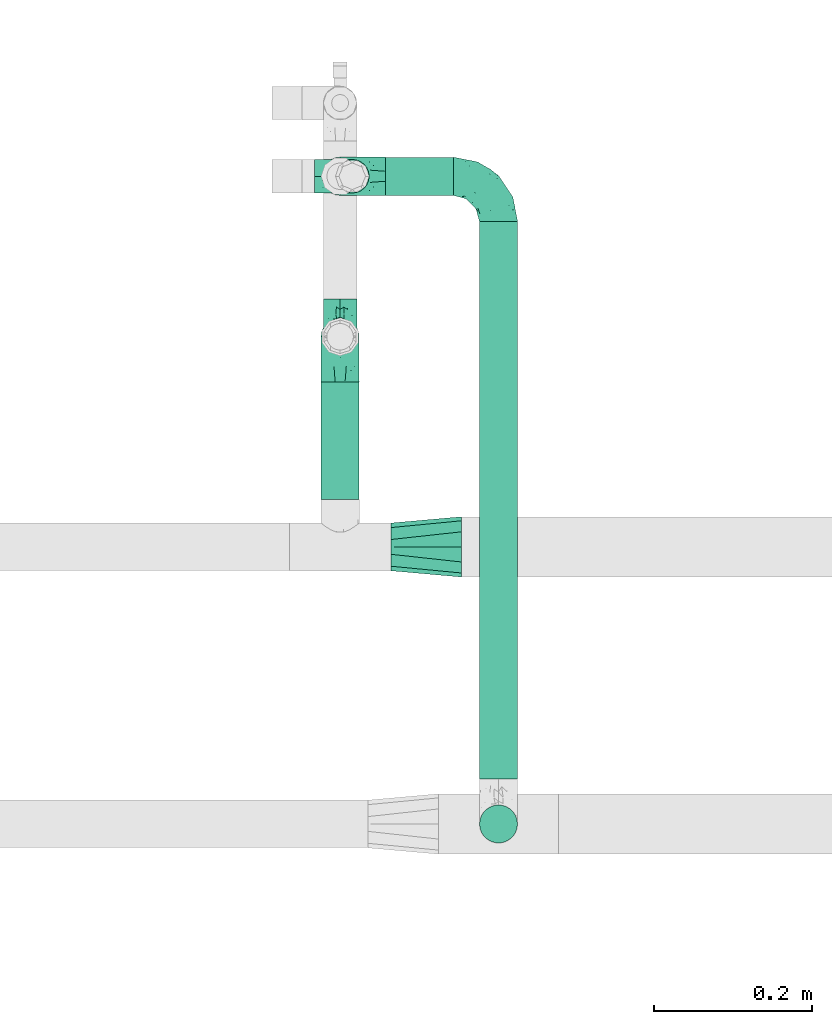
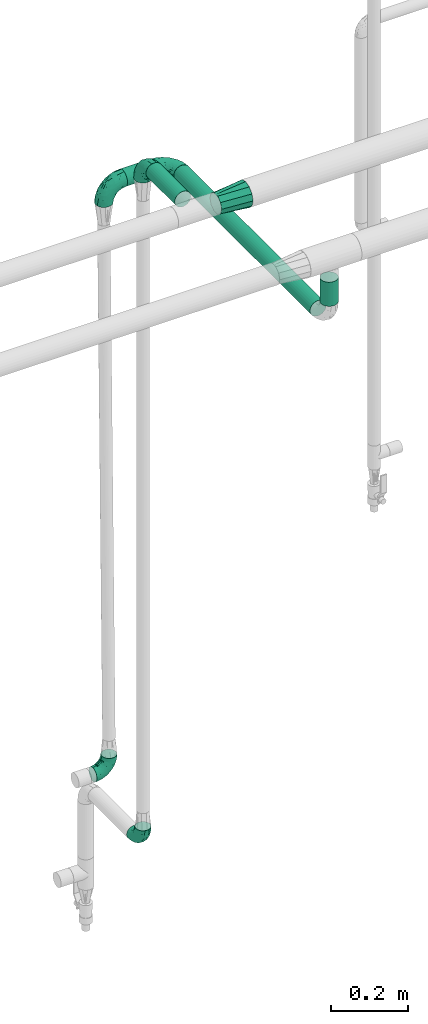
# One storey, part 565 of 827: 6 flow fittings, 4 flow segments.
"""IFC2X3 building model written with IfcOpenShell, lengths in millimetres."""

from ifc_helpers import new_model, entity, si_unit, converted_unit, derived_unit, direction, frame, origin, origin_2d_with_axis, place, context, subcontext, project, spatial, circle, extrude, faceted_brep, source, transform, mapped, material, type_object, type_shapes, element, save


model = new_model("IFC2X3")

# Units and contexts
model_context = context("Model", 3, precision=0.01, world=origin(), true_north=direction((6.12303176911189e-17, 1.0)))
body_context = subcontext(model_context, "Body", "Model", "MODEL_VIEW")
ifc_project = project(units=[si_unit("LENGTHUNIT", "METRE", prefix="MILLI"), si_unit("AREAUNIT", "SQUARE_METRE"), si_unit("VOLUMEUNIT", "CUBIC_METRE"), converted_unit("PLANEANGLEUNIT", "DEGREE", entity("IfcRatioMeasure", 0.0174532925199433), si_unit("PLANEANGLEUNIT", "RADIAN"), dimensions=[0, 0, 0, 0, 0, 0, 0]), si_unit("MASSUNIT", "GRAM", prefix="KILO"), derived_unit("MASSDENSITYUNIT", [(si_unit("MASSUNIT", "GRAM", prefix="KILO"), 1), (si_unit("LENGTHUNIT", "METRE"), -3)]), derived_unit("MOMENTOFINERTIAUNIT", [(si_unit("LENGTHUNIT", "METRE"), 4)]), si_unit("TIMEUNIT", "SECOND"), si_unit("FREQUENCYUNIT", "HERTZ"), si_unit("THERMODYNAMICTEMPERATUREUNIT", "DEGREE_CELSIUS"), derived_unit("THERMALTRANSMITTANCEUNIT", [(si_unit("MASSUNIT", "GRAM", prefix="KILO"), 1), (si_unit("THERMODYNAMICTEMPERATUREUNIT", "KELVIN"), -1), (si_unit("TIMEUNIT", "SECOND"), -3)]), derived_unit("VOLUMETRICFLOWRATEUNIT", [(si_unit("LENGTHUNIT", "METRE"), 3), (si_unit("TIMEUNIT", "SECOND"), -1)]), derived_unit("MASSFLOWRATEUNIT", [(si_unit("MASSUNIT", "GRAM", prefix="KILO"), 1), (si_unit("TIMEUNIT", "SECOND"), -1)]), derived_unit("ROTATIONALFREQUENCYUNIT", [(si_unit("TIMEUNIT", "SECOND"), -1)]), si_unit("ELECTRICCURRENTUNIT", "AMPERE"), si_unit("ELECTRICVOLTAGEUNIT", "VOLT"), si_unit("POWERUNIT", "WATT"), si_unit("FORCEUNIT", "NEWTON", prefix="KILO"), si_unit("ILLUMINANCEUNIT", "LUX"), si_unit("LUMINOUSFLUXUNIT", "LUMEN"), si_unit("LUMINOUSINTENSITYUNIT", "CANDELA"), derived_unit("USERDEFINED", [(si_unit("MASSUNIT", "GRAM", prefix="KILO"), -1), (si_unit("LENGTHUNIT", "METRE"), -2), (si_unit("TIMEUNIT", "SECOND"), 3), (si_unit("LUMINOUSFLUXUNIT", "LUMEN"), 1)]), derived_unit("LINEARVELOCITYUNIT", [(si_unit("LENGTHUNIT", "METRE"), 1), (si_unit("TIMEUNIT", "SECOND"), -1)]), si_unit("PRESSUREUNIT", "PASCAL"), derived_unit("USERDEFINED", [(si_unit("LENGTHUNIT", "METRE"), -2), (si_unit("MASSUNIT", "GRAM", prefix="KILO"), 1), (si_unit("TIMEUNIT", "SECOND"), -2)]), derived_unit("LINEARFORCEUNIT", [(si_unit("MASSUNIT", "GRAM", prefix="KILO"), 1), (si_unit("LENGTHUNIT", "METRE"), 1), (si_unit("TIMEUNIT", "SECOND"), -2), (si_unit("LENGTHUNIT", "METRE"), -1)]), derived_unit("PLANARFORCEUNIT", [(si_unit("MASSUNIT", "GRAM", prefix="KILO"), 1), (si_unit("LENGTHUNIT", "METRE"), 1), (si_unit("TIMEUNIT", "SECOND"), -2), (si_unit("LENGTHUNIT", "METRE"), -2)])], contexts=[model_context])

# Site, building, storey
site_placement = place(None, origin())
site = spatial("IfcSite", under=ifc_project, at=site_placement, CompositionType="ELEMENT")
building_placement = place(site_placement, origin())
building = spatial("IfcBuilding", under=site, at=building_placement, CompositionType="ELEMENT")
storey_placement = place(building_placement, frame((0.0, 0.0, 28200.0)))
storey = spatial("IfcBuildingStorey", under=building, at=storey_placement, Name="08", CompositionType="ELEMENT", Elevation=28200.0)

# Flow segments
pipe_segment_type = type_object("IfcPipeSegmentType", PredefinedType="NOTDEFINED")
flow_segment_1_placement = place(storey_placement, frame((13512.97, 15192.3, 2574.4)))
element("IfcFlowSegment", 1, at=flow_segment_1_placement, inside=storey, type_object=pipe_segment_type, context=body_context, shape_type="SweptSolid", body=[
    extrude(circle(Radius=24.0, at=origin_2d_with_axis()), frame((0.0, 25.6, 25.6), z_axis=(1.0, 0.0, 0.0), x_axis=(0.0, -1.0, 0.0)), (0.0, 0.0, 1.0), 85.9849158073314),
])
flow_segment_2_placement = place(storey_placement, frame((13430.37, 14809.89, 2774.4)))
element("IfcFlowSegment", 2, at=flow_segment_2_placement, inside=storey, type_object=pipe_segment_type, context=body_context, shape_type="SweptSolid", body=[
    extrude(circle(Radius=24.0, at=origin_2d_with_axis()), frame((25.6, 0.0, 25.6), z_axis=(0.0, 1.0, 0.0), x_axis=(1.0, 0.0, 0.0)), (0.0, 0.0, 1.0), 148.314300623279),
])
flow_segment_3_placement = place(storey_placement, frame((13630.36, 14457.0, 2574.4)))
element("IfcFlowSegment", 3, at=flow_segment_3_placement, inside=storey, type_object=pipe_segment_type, context=body_context, shape_type="SweptSolid", body=[
    extrude(circle(Radius=24.0, at=origin_2d_with_axis()), frame((25.6, 0.0, 25.61), z_axis=(0.0, 1.0, -2.41535411879e-05), x_axis=(-1.0, 0.0, 0.0)), (0.0, 0.0, 1.0), 703.896986835568),
])
flow_segment_4_placement = place(storey_placement, frame((13630.36, 14374.4, 2657.01)))
element("IfcFlowSegment", 4, at=flow_segment_4_placement, inside=storey, type_object=pipe_segment_type, context=body_context, shape_type="SweptSolid", body=[
    extrude(circle(Radius=24.0, at=origin_2d_with_axis()), frame((25.6, 25.6, 0.0)), (0.0, 0.0, 1.0), 75.9503658345094),
])

# Flow fittings
ifc_material = material()
pipe_fitting_type_1 = type_object("IfcPipeFittingType", Name="ADSK_1", PredefinedType="NOTDEFINED", material=ifc_material)
shared_shape_1 = source(origin(), body_context, "Body", "Brep", [
    faceted_brep([(-57.0, 12.07, -20.91), (-57.0, 6.25, -23.33), (-57.0, 0.0, -24.15), (-57.0, -6.25, -23.33), (-57.0, -12.08, -20.91), (-57.0, -17.08, -17.08), (-57.0, -20.91, -12.08), (-57.0, -23.33, -6.25), (-57.0, -24.15, 0.0), (-57.0, -23.33, 6.25), (-57.0, -20.91, 12.07), (-57.0, -17.08, 17.08), (-57.0, -12.08, 20.91), (-57.0, -6.25, 23.33), (-57.0, 0.0, 24.15), (-57.0, 6.25, 23.33), (-57.0, 12.07, 20.91), (-57.0, 17.08, 17.08), (-57.0, 20.91, 12.07), (-57.0, 23.33, 6.25), (-57.0, 24.15, 0.0), (-57.0, 23.33, -6.25), (-57.0, 20.91, -12.08), (-57.0, 17.08, -17.08), (0.0, 57.0, -24.15), (-6.25, 57.0, -23.33), (-12.07, 57.0, -20.91), (-17.08, 57.0, -17.08), (-20.91, 57.0, -12.08), (-23.33, 57.0, -6.25), (-24.15, 57.0, 0.0), (-23.33, 57.0, 6.25), (-20.91, 57.0, 12.07), (-17.08, 57.0, 17.08), (-12.07, 57.0, 20.91), (-6.25, 57.0, 23.33), (0.0, 57.0, 24.15), (6.25, 57.0, 23.33), (12.08, 57.0, 20.91), (17.08, 57.0, 17.08), (20.91, 57.0, 12.07), (23.33, 57.0, 6.25), (24.15, 57.0, 0.0), (23.33, 57.0, -6.25), (20.91, 57.0, -12.08), (17.08, 57.0, -17.08), (12.08, 57.0, -20.91), (6.25, 57.0, -23.33), (14.9, 21.14, 6.17), (13.61, 24.64, 12.48), (6.23, 8.95, 8.98), (-41.47, -21.06, 0.0), (-41.92, -18.38, 13.72), (-24.64, -13.61, 12.48), (-37.37, -13.24, 18.15), (-6.8, -4.93, 8.18), (-21.76, -15.19, 6.22), (-12.78, -9.18, 0.0), (-37.73, -20.51, 7.75), (-7.38, 7.38, 20.24), (-23.37, -4.26, 20.42), (-11.9, -3.19, 15.86), (-42.14, -8.7, 21.82), (13.24, 37.37, 18.15), (9.33, 23.53, 16.85), (4.26, 23.37, 20.42), (2.77, 10.92, 15.55), (-29.46, 0.91, 23.52), (-44.13, 20.56, 15.69), (-39.25, 26.33, 10.88), (-49.02, 22.92, 9.96), (-34.58, 23.87, 17.15), (-15.8, 6.8, 22.81), (-8.67, 20.47, 23.88), (-18.12, 12.9, 24.08), (-48.29, 14.92, 19.65), (-44.06, -2.85, 23.78), (-9.23, 48.95, 22.58), (-3.78, 42.74, 24.07), (-40.34, 4.26, 24.09), (-44.02, 26.14, 5.46), (-44.04, 9.88, 22.74), (-4.95, 16.87, 22.52), (-2.75, 1.43, 12.5), (-25.48, 40.98, 10.71), (20.51, 37.73, 7.75), (18.38, 41.92, 13.72), (8.7, 42.14, 21.82), (-25.95, -17.97, 0.0), (2.85, 44.06, 23.78), (21.06, 41.47, 0.0), (17.97, 25.95, 0.0), (-24.04, -9.27, 17.13), (-33.26, 33.26, 5.86), (-28.55, 40.57, 0.0), (-40.57, 28.55, 0.0), (-25.29, 47.19, 4.06), (-27.01, 31.1, 16.77), (-15.7, 43.95, 19.9), (-20.27, 45.22, 15.61), (-30.53, 31.98, 12.64), (-11.28, 38.33, 22.92), (-9.97, 27.88, 24.09), (-20.15, 30.26, 21.25), (-31.25, 11.75, 23.64), (-28.75, 7.23, 24.15), (-29.53, 18.06, 22.27), (-28.44, 24.21, 20.02), (-37.55, 17.7, 20.26), (-15.88, 29.25, 22.99), (-20.82, 20.82, 23.44), (-0.91, 29.46, 23.52), (-13.5, -7.67, 12.04), (1.49, 1.56, 5.16), (8.86, 10.35, 4.59), (0.38, -0.38, 0.0), (9.18, 12.78, 0.0), (-37.37, -13.24, -18.15), (8.86, 10.35, -4.59), (-45.22, 20.27, -15.61), (-43.95, 15.7, -19.9), (-38.33, 11.28, -22.92), (-48.95, 9.23, -22.58), (-47.19, 25.29, -4.06), (-33.26, 33.26, -5.86), (18.38, 41.92, -13.72), (-30.26, 20.15, -21.25), (2.85, 44.06, -23.78), (-4.26, 40.34, -24.09), (-40.98, 25.48, -10.71), (-41.92, -18.38, -13.72), (9.25, 23.5, -16.92), (4.26, 23.37, -20.42), (13.24, 37.37, -18.15), (-37.73, -20.51, -7.75), (-11.75, 31.25, -23.64), (-7.23, 28.75, -24.15), (-12.9, 18.12, -24.08), (8.7, 42.14, -21.82), (-44.06, -2.85, -23.78), (-6.8, 15.8, -22.81), (-20.47, 8.67, -23.88), (-24.64, -13.61, -12.48), (-42.74, 3.78, -24.07), (-18.06, 29.53, -22.27), (-24.21, 28.44, -20.02), (-27.88, 9.97, -24.09), (-31.1, 27.01, -16.77), (-26.14, 44.02, -5.46), (14.9, 21.14, -6.17), (20.51, 37.73, -7.75), (-9.88, 44.04, -22.74), (-20.56, 44.13, -15.69), (-21.76, -15.19, -6.22), (-13.5, -7.67, -12.04), (-24.14, -9.76, -16.74), (-11.9, -3.19, -15.86), (-14.92, 48.29, -19.65), (-23.37, -4.26, -20.42), (-0.91, 29.46, -23.52), (-26.33, 39.25, -10.88), (-23.87, 34.58, -17.15), (-42.14, -8.7, -21.82), (-22.92, 49.02, -9.96), (13.61, 24.64, -12.48), (-31.98, 30.53, -12.64), (-16.87, 4.95, -22.52), (-17.7, 37.55, -20.26), (-29.25, 15.88, -22.99), (-20.82, 20.82, -23.44), (-29.46, 0.91, -23.52), (-7.38, 7.38, -20.24), (2.77, 10.92, -15.55), (6.23, 8.95, -8.98), (-6.8, -4.93, -8.18), (-2.81, 1.41, -12.54), (1.49, 1.56, -5.16)], [[[0, 1, 2, 3, 4, 5, 6, 7, 8, 9, 10, 11, 12, 13, 14, 15, 16, 17, 18, 19, 20, 21, 22, 23]], [[24, 25, 26, 27, 28, 29, 30, 31, 32, 33, 34, 35, 36, 37, 38, 39, 40, 41, 42, 43, 44, 45, 46, 47]], [[48, 49, 50]], [[9, 8, 51]], [[52, 53, 54]], [[55, 56, 57]], [[10, 58, 52]], [[9, 58, 10]], [[59, 60, 61]], [[54, 12, 11]], [[54, 62, 12]], [[63, 39, 38]], [[64, 65, 66]], [[62, 60, 67]], [[68, 69, 70]], [[71, 69, 68]], [[72, 73, 74]], [[16, 75, 17]], [[13, 76, 14]], [[35, 77, 78]], [[14, 79, 15]], [[17, 68, 18]], [[14, 76, 79]], [[20, 19, 80]], [[70, 19, 18]], [[81, 15, 79]], [[15, 81, 16]], [[73, 72, 82]], [[66, 83, 50]], [[32, 31, 84]], [[85, 86, 49]], [[63, 87, 65]], [[56, 58, 88]], [[36, 89, 37]], [[85, 41, 40]], [[36, 35, 78]], [[90, 41, 85]], [[40, 39, 86]], [[12, 62, 13]], [[86, 85, 40]], [[48, 85, 49]], [[85, 91, 90]], [[87, 38, 37]], [[92, 60, 54]], [[80, 69, 93]], [[93, 94, 95]], [[10, 52, 11]], [[94, 96, 30]], [[97, 98, 99]], [[80, 93, 95]], [[100, 97, 84]], [[99, 98, 33]], [[101, 102, 78]], [[103, 101, 98]], [[96, 31, 30]], [[77, 98, 101]], [[77, 35, 34]], [[34, 33, 98]], [[9, 51, 58]], [[87, 63, 38]], [[104, 105, 74]], [[106, 103, 107]], [[106, 81, 104]], [[75, 68, 17]], [[108, 107, 71]], [[33, 32, 99]], [[109, 103, 110]], [[101, 109, 102]], [[89, 78, 111]], [[53, 52, 58]], [[54, 11, 52]], [[60, 62, 54]], [[88, 58, 51]], [[76, 62, 67]], [[53, 112, 92]], [[60, 59, 72]], [[39, 63, 86]], [[49, 86, 63]], [[89, 87, 37]], [[42, 41, 90]], [[111, 82, 65]], [[111, 65, 87]], [[65, 59, 66]], [[104, 81, 79]], [[75, 81, 108]], [[32, 84, 99]], [[97, 99, 84]], [[98, 97, 103]], [[106, 107, 108]], [[74, 102, 110]], [[111, 78, 102]], [[74, 110, 104]], [[74, 67, 72]], [[61, 92, 112]], [[66, 59, 61]], [[56, 53, 58]], [[66, 50, 49]], [[61, 112, 83]], [[66, 49, 64]], [[78, 89, 36]], [[87, 89, 111]], [[62, 76, 13]], [[79, 76, 67]], [[100, 93, 69]], [[96, 93, 84]], [[55, 113, 50]], [[113, 114, 50]], [[104, 79, 105]], [[106, 104, 110]], [[20, 80, 95]], [[85, 48, 91]], [[115, 114, 113]], [[116, 91, 48]], [[70, 80, 19]], [[93, 96, 94]], [[84, 31, 96]], [[103, 106, 110]], [[81, 106, 108]], [[103, 97, 107]], [[71, 107, 97]], [[71, 97, 100]], [[108, 71, 68]], [[79, 67, 105]], [[67, 74, 105]], [[115, 113, 57]], [[112, 56, 55]], [[56, 88, 57]], [[60, 72, 67]], [[82, 72, 59]], [[65, 82, 59]], [[82, 111, 73]], [[111, 102, 73]], [[102, 74, 73]], [[81, 75, 16]], [[68, 75, 108]], [[68, 70, 18]], [[80, 70, 69]], [[98, 77, 34]], [[78, 77, 101]], [[93, 100, 84]], [[71, 100, 69]], [[102, 109, 110]], [[101, 103, 109]], [[53, 92, 54]], [[61, 60, 92]], [[56, 112, 53]], [[83, 112, 55]], [[50, 83, 55]], [[61, 83, 66]], [[49, 63, 64]], [[65, 64, 63]], [[57, 113, 55]], [[114, 115, 116]], [[116, 48, 114]], [[48, 50, 114]], [[117, 5, 4]], [[116, 115, 118]], [[119, 120, 23]], [[121, 122, 120]], [[95, 123, 20]], [[0, 23, 120]], [[124, 95, 94]], [[125, 45, 44]], [[121, 120, 126]], [[24, 127, 128]], [[22, 21, 129]], [[0, 122, 1]], [[5, 117, 130]], [[131, 132, 133]], [[134, 88, 51]], [[135, 136, 137]], [[6, 5, 130]], [[46, 138, 47]], [[139, 3, 2]], [[140, 141, 137]], [[6, 134, 7]], [[134, 130, 142]], [[143, 2, 1]], [[144, 126, 145]], [[121, 146, 143]], [[147, 120, 119]], [[94, 148, 124]], [[149, 150, 91]], [[30, 29, 148]], [[151, 25, 128]], [[27, 152, 28]], [[134, 153, 88]], [[154, 155, 156]], [[27, 26, 157]], [[151, 26, 25]], [[155, 158, 156]], [[24, 47, 127]], [[1, 122, 143]], [[138, 132, 159]], [[160, 152, 161]], [[24, 128, 25]], [[46, 133, 138]], [[162, 117, 4]], [[148, 160, 124]], [[152, 160, 163]], [[154, 142, 155]], [[45, 125, 133]], [[133, 46, 45]], [[125, 164, 133]], [[51, 7, 134]], [[42, 90, 43]], [[165, 147, 129]], [[153, 134, 142]], [[43, 150, 44]], [[162, 4, 3]], [[141, 140, 166]], [[117, 162, 158]], [[163, 29, 28]], [[43, 90, 150]], [[123, 21, 20]], [[144, 151, 135]], [[157, 152, 27]], [[167, 145, 161]], [[23, 22, 119]], [[168, 126, 169]], [[121, 168, 146]], [[139, 143, 170]], [[142, 130, 117]], [[8, 7, 51]], [[134, 6, 130]], [[139, 162, 3]], [[170, 166, 158]], [[170, 158, 162]], [[158, 171, 156]], [[44, 150, 125]], [[91, 150, 90]], [[164, 125, 150]], [[132, 138, 133]], [[127, 138, 159]], [[131, 164, 172]], [[132, 171, 140]], [[135, 151, 128]], [[157, 151, 167]], [[22, 129, 119]], [[147, 119, 129]], [[120, 147, 126]], [[144, 145, 167]], [[137, 146, 169]], [[170, 143, 146]], [[137, 169, 135]], [[137, 159, 140]], [[171, 172, 156]], [[173, 174, 175]], [[156, 175, 154]], [[174, 57, 153]], [[132, 172, 171]], [[172, 164, 173]], [[143, 139, 2]], [[162, 139, 170]], [[138, 127, 47]], [[128, 127, 159]], [[165, 124, 160]], [[123, 124, 129]], [[149, 173, 164]], [[176, 174, 173]], [[135, 128, 136]], [[144, 135, 169]], [[150, 149, 164]], [[176, 118, 115]], [[149, 91, 116]], [[30, 148, 94]], [[163, 148, 29]], [[124, 123, 95]], [[129, 21, 123]], [[126, 144, 169]], [[151, 144, 167]], [[126, 147, 145]], [[161, 145, 147]], [[161, 147, 165]], [[167, 161, 152]], [[128, 159, 136]], [[159, 137, 136]], [[154, 153, 142]], [[132, 140, 159]], [[174, 176, 57]], [[57, 88, 153]], [[166, 140, 171]], [[158, 166, 171]], [[166, 170, 141]], [[170, 146, 141]], [[146, 137, 141]], [[151, 157, 26]], [[152, 157, 167]], [[152, 163, 28]], [[148, 163, 160]], [[120, 122, 0]], [[143, 122, 121]], [[124, 165, 129]], [[161, 165, 160]], [[146, 168, 169]], [[121, 126, 168]], [[142, 117, 155]], [[158, 155, 117]], [[175, 156, 172]], [[153, 154, 174]], [[173, 175, 172]], [[174, 154, 175]], [[164, 131, 133]], [[172, 132, 131]], [[176, 173, 118]], [[57, 176, 115]], [[173, 149, 118]], [[149, 116, 118]]]),
])
type_shapes(pipe_fitting_type_1, [shared_shape_1])
for number, where, z_axis, x_axis, name in (
    (5, (13455.97, 15217.9, 2600.0), (0.0, 1.0, 0.0), (0.0, 0.0, 1.0), "ADSK_1"),
    (6, (13655.95, 15217.9, 2600.0), (0.0, 0.0, 1.0), (0.0, 1.0, 0.0), "ADSK_1"),
    (7, (13455.97, 15015.21, 2800.0), (-1.0, 0.0, 0.0), (0.0, 1.0, 0.0), "ADSK_1"),
):
    element("IfcFlowFitting", number, at=place(storey_placement, frame(where, z_axis=z_axis, x_axis=x_axis)), inside=storey, type_object=pipe_fitting_type_1, material=ifc_material, Name=name, ObjectType="ADSK_1", context=body_context, shape_type="MappedRepresentation", body=[
        mapped(shared_shape_1, transform((0.0, 0.0, 0.0), scale=1.0)),
    ])
pipe_fitting_type_2 = type_object("IfcPipeFittingType", Name="ADSK_1", PredefinedType="NOTDEFINED", material=ifc_material)
shared_shape_2 = source(origin(), body_context, "Body", "Brep", [
    faceted_brep([(-48.0, 10.6, -18.36), (-48.0, 5.49, -20.48), (-48.0, 0.0, -21.2), (-48.0, -5.49, -20.48), (-48.0, -10.6, -18.36), (-48.0, -14.99, -14.99), (-48.0, -18.36, -10.6), (-48.0, -20.48, -5.49), (-48.0, -21.2, 0.0), (-48.0, -20.48, 5.49), (-48.0, -18.36, 10.6), (-48.0, -14.99, 14.99), (-48.0, -10.6, 18.36), (-48.0, -5.49, 20.48), (-48.0, 0.0, 21.2), (-48.0, 5.49, 20.48), (-48.0, 10.6, 18.36), (-48.0, 14.99, 14.99), (-48.0, 18.36, 10.6), (-48.0, 20.48, 5.49), (-48.0, 21.2, 0.0), (-48.0, 20.48, -5.49), (-48.0, 18.36, -10.6), (-48.0, 14.99, -14.99), (0.0, 48.0, -21.2), (-5.49, 48.0, -20.48), (-10.6, 48.0, -18.36), (-14.99, 48.0, -14.99), (-18.36, 48.0, -10.6), (-20.48, 48.0, -5.49), (-21.2, 48.0, 0.0), (-20.48, 48.0, 5.49), (-18.36, 48.0, 10.6), (-14.99, 48.0, 14.99), (-10.6, 48.0, 18.36), (-5.49, 48.0, 20.48), (0.0, 48.0, 21.2), (5.49, 48.0, 20.48), (10.6, 48.0, 18.36), (14.99, 48.0, 14.99), (18.36, 48.0, 10.6), (20.48, 48.0, 5.49), (21.2, 48.0, 0.0), (20.48, 48.0, -5.49), (18.36, 48.0, -10.6), (14.99, 48.0, -14.99), (10.6, 48.0, -18.36), (5.49, 48.0, -20.48), (-35.25, -16.22, 12.01), (-34.76, -18.57, 0.0), (-20.87, -12.37, 10.9), (-31.49, -11.78, 15.9), (-37.0, -2.58, 20.86), (-33.89, 3.62, 21.15), (-31.81, -18.14, 6.76), (-5.78, 5.78, 17.67), (-19.42, -4.1, 17.86), (-9.6, -3.39, 13.73), (-35.44, -7.73, 19.13), (11.78, 31.49, 15.9), (-5.93, -5.46, 6.95), (-18.45, -13.78, 5.46), (-10.29, -8.43, 0.0), (-24.6, 0.55, 20.62), (-37.28, 17.94, 13.81), (-33.38, 22.85, 9.59), (-41.46, 20.06, 8.75), (-29.51, 20.45, 15.16), (-15.04, 10.79, 21.13), (-7.08, 16.98, 20.93), (-8.39, 23.51, 21.15), (-40.86, 13.03, 17.26), (-8.05, 41.26, 19.83), (-3.21, 35.97, 21.14), (8.53, 19.66, 14.74), (4.1, 19.42, 17.86), (-37.72, 22.66, 4.78), (-37.07, 8.58, 19.98), (-13.0, 5.43, 19.97), (-3.78, 13.93, 19.7), (3.02, 8.69, 13.43), (-2.27, -0.05, 10.65), (6.22, 6.99, 7.09), (-22.25, 34.6, 9.45), (18.14, 31.81, 6.76), (16.22, 35.25, 12.01), (12.37, 20.87, 10.9), (7.73, 35.44, 19.13), (-21.52, -15.93, 0.0), (2.58, 37.0, 20.86), (18.57, 34.76, 0.0), (13.78, 18.45, 5.46), (15.93, 21.52, 0.0), (-20.03, -8.54, 14.9), (-28.6, 28.6, 5.16), (-24.79, 34.6, 0.0), (-34.6, 24.79, 0.0), (-22.81, 37.41, 4.68), (-23.36, 26.33, 14.79), (-13.68, 37.05, 17.49), (-17.72, 38.12, 13.73), (-26.25, 27.3, 11.24), (-9.71, 32.34, 20.14), (-17.26, 25.6, 18.71), (-26.33, 9.99, 20.77), (-24.06, 6.05, 21.2), (-25.02, 15.46, 19.56), (-24.3, 20.72, 17.57), (-31.95, 15.23, 17.8), (-13.53, 24.7, 20.21), (-17.6, 17.6, 20.6), (-0.55, 24.6, 20.62), (-11.41, -7.48, 10.43), (0.93, -0.93, 0.0), (8.43, 10.29, 0.0), (-11.41, -7.48, -10.43), (-20.1, -8.84, -14.66), (-9.6, -3.39, -13.73), (7.73, 35.44, -19.13), (4.1, 19.42, -17.86), (-0.55, 24.6, -20.62), (-38.12, 17.72, -13.73), (-37.05, 13.68, -17.49), (-32.34, 9.71, -20.14), (-41.26, 8.05, -19.83), (-37.41, 22.81, -4.68), (-23.51, 8.39, -21.15), (-35.97, 3.21, -21.14), (-28.6, 28.6, -5.16), (-31.81, -18.14, -6.76), (-18.45, -13.78, -5.46), (-25.6, 17.26, -18.71), (-19.42, -4.1, -17.86), (-17.94, 37.28, -13.81), (-22.85, 33.38, -9.59), (-20.06, 41.46, -8.75), (-31.49, -11.78, -15.9), (-35.25, -16.22, -12.01), (8.53, 19.66, -14.74), (11.78, 31.49, -15.9), (-9.99, 26.33, -20.77), (-6.05, 24.06, -21.2), (-10.79, 15.04, -21.13), (-37.0, -2.58, -20.86), (-16.98, 7.08, -20.93), (-5.43, 13.0, -19.97), (-13.93, 3.78, -19.7), (-20.87, -12.37, -10.9), (-26.33, 23.36, -14.79), (-22.66, 37.72, -4.78), (13.78, 18.45, -5.46), (18.14, 31.81, -6.76), (-15.46, 25.02, -19.56), (-20.72, 24.3, -17.57), (16.22, 35.25, -12.01), (-13.03, 40.86, -17.26), (-8.58, 37.07, -19.98), (2.58, 37.0, -20.86), (-3.62, 33.89, -21.15), (-34.6, 22.25, -9.45), (6.22, 6.99, -7.09), (-20.45, 29.51, -15.16), (-35.44, -7.73, -19.13), (12.37, 20.87, -10.9), (-27.3, 26.25, -11.24), (-15.23, 31.95, -17.8), (-24.7, 13.53, -20.21), (-24.6, 0.55, -20.62), (-5.78, 5.78, -17.67), (-17.6, 17.6, -20.6), (3.02, 8.69, -13.43), (-5.93, -5.46, -6.95), (-2.27, -0.05, -10.65)], [[[0, 1, 2, 3, 4, 5, 6, 7, 8, 9, 10, 11, 12, 13, 14, 15, 16, 17, 18, 19, 20, 21, 22, 23]], [[24, 25, 26, 27, 28, 29, 30, 31, 32, 33, 34, 35, 36, 37, 38, 39, 40, 41, 42, 43, 44, 45, 46, 47]], [[10, 48, 11]], [[9, 8, 49]], [[48, 50, 51]], [[14, 52, 53]], [[10, 54, 48]], [[9, 54, 10]], [[55, 56, 57]], [[51, 12, 11]], [[51, 58, 12]], [[59, 39, 38]], [[60, 61, 62]], [[58, 56, 63]], [[64, 65, 66]], [[67, 65, 64]], [[68, 69, 70]], [[16, 71, 17]], [[13, 52, 14]], [[35, 72, 73]], [[14, 53, 15]], [[17, 64, 18]], [[74, 59, 75]], [[20, 19, 76]], [[66, 19, 18]], [[77, 15, 53]], [[15, 77, 16]], [[69, 78, 79]], [[80, 81, 82]], [[32, 31, 83]], [[84, 85, 86]], [[59, 87, 75]], [[61, 54, 88]], [[36, 89, 37]], [[84, 41, 40]], [[36, 35, 73]], [[90, 41, 84]], [[40, 39, 85]], [[12, 58, 13]], [[85, 84, 40]], [[91, 84, 86]], [[84, 92, 90]], [[87, 38, 37]], [[93, 56, 51]], [[65, 94, 76]], [[94, 95, 96]], [[84, 91, 92]], [[95, 97, 30]], [[98, 99, 100]], [[76, 94, 96]], [[101, 98, 83]], [[100, 99, 33]], [[102, 70, 73]], [[103, 102, 99]], [[94, 97, 95]], [[72, 99, 102]], [[72, 35, 34]], [[34, 33, 99]], [[9, 49, 54]], [[87, 59, 38]], [[104, 105, 68]], [[106, 103, 107]], [[106, 77, 104]], [[71, 64, 17]], [[108, 107, 67]], [[33, 32, 100]], [[109, 103, 110]], [[102, 109, 70]], [[89, 73, 111]], [[50, 48, 54]], [[51, 11, 48]], [[56, 58, 51]], [[88, 54, 49]], [[52, 58, 63]], [[50, 112, 93]], [[56, 55, 78]], [[39, 59, 85]], [[86, 85, 59]], [[89, 87, 37]], [[42, 41, 90]], [[111, 79, 75]], [[111, 75, 87]], [[75, 55, 80]], [[104, 77, 53]], [[71, 77, 108]], [[32, 83, 100]], [[98, 100, 83]], [[99, 98, 103]], [[106, 107, 108]], [[68, 70, 110]], [[111, 73, 70]], [[68, 110, 104]], [[68, 63, 78]], [[57, 93, 112]], [[80, 55, 57]], [[61, 50, 54]], [[80, 82, 86]], [[81, 57, 112]], [[74, 86, 59]], [[60, 113, 82]], [[82, 114, 91]], [[101, 94, 65]], [[97, 94, 83]], [[73, 89, 36]], [[87, 89, 111]], [[58, 52, 13]], [[53, 52, 63]], [[104, 53, 105]], [[106, 104, 110]], [[20, 76, 96]], [[76, 19, 66]], [[103, 106, 110]], [[77, 106, 108]], [[103, 98, 107]], [[67, 107, 98]], [[67, 98, 101]], [[108, 67, 64]], [[53, 63, 105]], [[63, 68, 105]], [[83, 31, 97]], [[30, 97, 31]], [[62, 113, 60]], [[112, 61, 60]], [[61, 88, 62]], [[86, 82, 91]], [[56, 78, 63]], [[114, 82, 113]], [[114, 92, 91]], [[79, 78, 55]], [[75, 79, 55]], [[69, 79, 111]], [[70, 69, 111]], [[78, 69, 68]], [[77, 71, 16]], [[64, 71, 108]], [[64, 66, 18]], [[76, 66, 65]], [[99, 72, 34]], [[73, 72, 102]], [[94, 101, 83]], [[67, 101, 65]], [[75, 80, 74]], [[80, 86, 74]], [[70, 109, 110]], [[102, 103, 109]], [[50, 93, 51]], [[57, 56, 93]], [[61, 112, 50]], [[81, 112, 60]], [[82, 81, 60]], [[80, 57, 81]], [[115, 116, 117]], [[118, 119, 120]], [[121, 122, 23]], [[123, 124, 122]], [[96, 125, 20]], [[123, 126, 127]], [[128, 96, 95]], [[129, 130, 88]], [[123, 122, 131]], [[116, 132, 117]], [[133, 134, 135]], [[0, 124, 1]], [[5, 136, 137]], [[138, 119, 139]], [[129, 88, 49]], [[140, 141, 142]], [[6, 5, 137]], [[46, 118, 47]], [[143, 3, 2]], [[144, 145, 146]], [[6, 129, 7]], [[129, 137, 147]], [[127, 2, 1]], [[148, 122, 121]], [[128, 125, 96]], [[134, 128, 149]], [[95, 149, 128]], [[150, 151, 92]], [[30, 29, 149]], [[152, 131, 153]], [[27, 133, 28]], [[154, 45, 44]], [[136, 5, 4]], [[27, 26, 155]], [[156, 26, 25]], [[24, 157, 158]], [[24, 47, 157]], [[22, 21, 159]], [[160, 150, 114]], [[134, 133, 161]], [[142, 144, 126]], [[46, 139, 118]], [[162, 136, 4]], [[156, 25, 158]], [[1, 124, 127]], [[115, 147, 116]], [[45, 154, 139]], [[139, 46, 45]], [[154, 163, 139]], [[162, 4, 3]], [[42, 90, 43]], [[130, 129, 147]], [[49, 7, 129]], [[43, 151, 44]], [[0, 23, 122]], [[24, 158, 25]], [[136, 162, 132]], [[135, 29, 28]], [[43, 90, 151]], [[164, 148, 159]], [[152, 156, 140]], [[155, 133, 27]], [[165, 153, 161]], [[23, 22, 121]], [[123, 131, 166]], [[123, 166, 126]], [[143, 127, 167]], [[147, 137, 136]], [[8, 7, 49]], [[129, 6, 137]], [[143, 162, 3]], [[167, 146, 132]], [[167, 132, 162]], [[132, 168, 117]], [[44, 151, 154]], [[92, 151, 90]], [[163, 154, 151]], [[119, 118, 139]], [[157, 118, 120]], [[138, 139, 163]], [[119, 168, 145]], [[140, 156, 158]], [[155, 156, 165]], [[22, 159, 121]], [[148, 121, 159]], [[122, 148, 131]], [[152, 153, 165]], [[142, 126, 169]], [[167, 127, 126]], [[142, 169, 140]], [[142, 120, 145]], [[168, 170, 117]], [[160, 171, 172]], [[115, 172, 171]], [[171, 62, 130]], [[119, 170, 168]], [[170, 163, 160]], [[150, 163, 151]], [[113, 171, 160]], [[164, 128, 134]], [[125, 128, 159]], [[127, 143, 2]], [[162, 143, 167]], [[118, 157, 47]], [[158, 157, 120]], [[140, 158, 141]], [[152, 140, 169]], [[30, 149, 95]], [[149, 29, 135]], [[131, 152, 169]], [[156, 152, 165]], [[131, 148, 153]], [[161, 153, 148]], [[161, 148, 164]], [[165, 161, 133]], [[158, 120, 141]], [[120, 142, 141]], [[159, 21, 125]], [[20, 125, 21]], [[115, 130, 147]], [[114, 113, 160]], [[62, 171, 113]], [[62, 88, 130]], [[160, 163, 150]], [[150, 92, 114]], [[119, 145, 120]], [[146, 145, 168]], [[132, 146, 168]], [[144, 146, 167]], [[126, 144, 167]], [[145, 144, 142]], [[156, 155, 26]], [[133, 155, 165]], [[133, 135, 28]], [[149, 135, 134]], [[122, 124, 0]], [[127, 124, 123]], [[128, 164, 159]], [[161, 164, 134]], [[163, 170, 138]], [[170, 119, 138]], [[131, 169, 166]], [[126, 166, 169]], [[147, 136, 116]], [[132, 116, 136]], [[172, 115, 117]], [[130, 115, 171]], [[117, 170, 172]], [[160, 172, 170]]]),
])
type_shapes(pipe_fitting_type_2, [shared_shape_2])
for number, where, z_axis, x_axis, name in (
    (8, (13455.97, 15015.21, 650.0), (-1.0, 0.0, 0.0), (0.0, -1.0, 0.0), "ADSK_1"),
    (9, (13471.37, 15217.9, 750.0), (0.0, -1.0, 0.0), (1.0, 0.0, 0.0), "ADSK_1"),
):
    element("IfcFlowFitting", number, at=place(storey_placement, frame(where, z_axis=z_axis, x_axis=x_axis)), inside=storey, type_object=pipe_fitting_type_2, material=ifc_material, Name=name, ObjectType="ADSK_1", context=body_context, shape_type="MappedRepresentation", body=[
        mapped(shared_shape_2, transform((0.0, 0.0, 0.0), scale=1.0)),
    ])
pipe_fitting_type_3 = type_object("IfcPipeFittingType", Name="ADSK_1", PredefinedType="NOTDEFINED", material=ifc_material)
shared_shape_3 = source(origin(), body_context, "Body", "Brep", [
    faceted_brep([(89.0, 32.95, -19.02), (89.0, 36.11, -7.24), (89.0, 38.05, 0.0), (89.0, 36.11, 7.24), (89.0, 32.95, 19.03), (89.0, 25.99, 25.99), (89.0, 19.02, 32.95), (89.0, 9.51, 35.5), (89.0, 0.0, 38.05), (89.0, -9.51, 35.5), (89.0, -19.03, 32.95), (89.0, -25.99, 25.99), (89.0, -32.95, 19.03), (89.0, -36.11, 7.24), (89.0, -38.05, 0.0), (89.0, -36.11, -7.24), (89.0, -32.95, -19.02), (89.0, -25.99, -25.99), (89.0, -19.03, -32.95), (89.0, -9.51, -35.5), (89.0, 0.0, -38.05), (89.0, 9.51, -35.5), (89.0, 19.02, -32.95), (89.0, 25.99, -25.99), (0.0, 30.15, 0.0), (0.0, 27.27, -8.86), (0.0, 24.39, -17.72), (0.0, 16.85, -23.2), (0.0, 9.32, -28.67), (0.0, 0.0, -28.67), (0.0, -9.32, -28.67), (0.0, -16.85, -23.2), (0.0, -24.39, -17.72), (0.0, -27.27, -8.86), (0.0, -30.15, 0.0), (0.0, -27.27, 8.86), (0.0, -24.39, 17.72), (0.0, -16.85, 23.2), (0.0, -9.32, 28.67), (0.0, 0.0, 28.67), (0.0, 9.32, 28.67), (0.0, 16.85, 23.2), (0.0, 24.39, 17.72), (0.0, 27.27, 8.86)], [[[0, 1, 2, 3, 4, 5, 6, 7, 8, 9, 10, 11, 12, 13, 14, 15, 16, 17, 18, 19, 20, 21, 22, 23]], [[24, 25, 26, 27, 28, 29, 30, 31, 32, 33, 34, 35, 36, 37, 38, 39, 40, 41, 42, 43]], [[16, 33, 32]], [[28, 21, 29]], [[29, 19, 30]], [[19, 18, 30]], [[17, 32, 31]], [[34, 15, 14]], [[15, 34, 33]], [[22, 28, 27]], [[16, 15, 33]], [[0, 25, 1]], [[31, 30, 18]], [[1, 25, 24]], [[26, 0, 23]], [[24, 2, 1]], [[28, 22, 21]], [[16, 32, 17]], [[27, 26, 23]], [[26, 25, 0]], [[31, 18, 17]], [[22, 27, 23]], [[29, 21, 20]], [[19, 29, 20]], [[4, 43, 42]], [[38, 9, 39]], [[39, 7, 40]], [[7, 6, 40]], [[5, 42, 41]], [[24, 3, 2]], [[3, 24, 43]], [[10, 38, 37]], [[4, 3, 43]], [[12, 35, 13]], [[41, 40, 6]], [[13, 35, 34]], [[36, 12, 11]], [[34, 14, 13]], [[38, 10, 9]], [[4, 42, 5]], [[37, 36, 11]], [[36, 35, 12]], [[41, 6, 5]], [[10, 37, 11]], [[39, 9, 8]], [[7, 39, 8]]]),
])
type_shapes(pipe_fitting_type_3, [shared_shape_3])
flow_fitting_placement = place(storey_placement, frame((13519.97, 14749.89, 2800.0)))
element("IfcFlowFitting", 10, at=flow_fitting_placement, inside=storey, type_object=pipe_fitting_type_3, material=ifc_material, Name="ADSK_1", ObjectType="ADSK_1", context=body_context, shape_type="MappedRepresentation", body=[
    mapped(shared_shape_3, transform((0.0, 0.0, 0.0), scale=1.0)),
])

save(model, "model.ifc")
